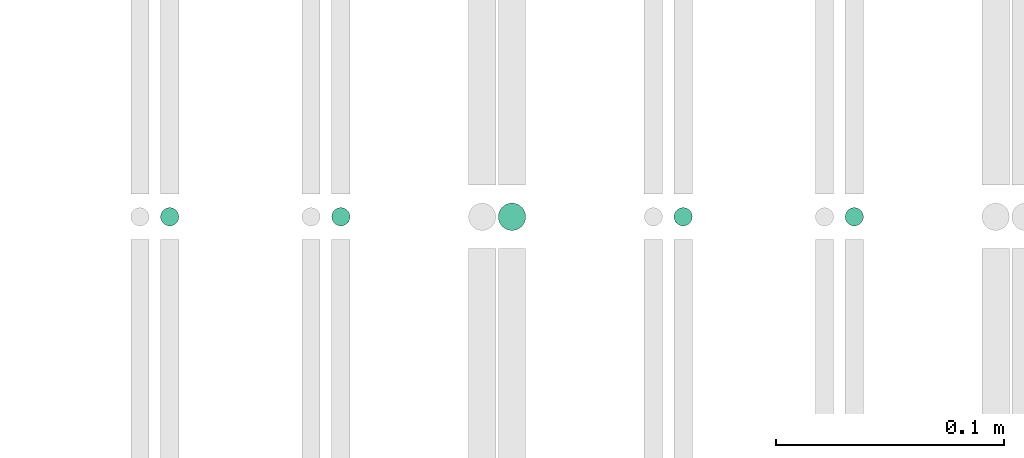
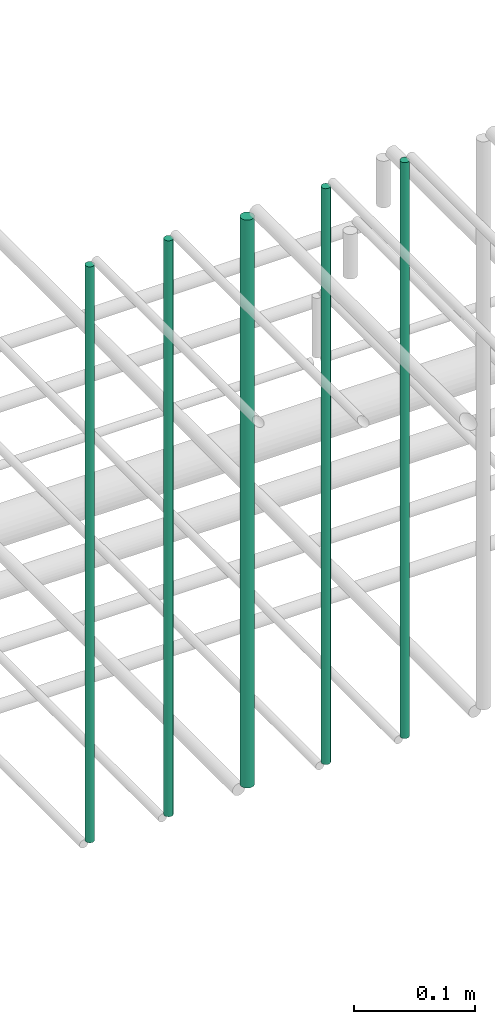
# One storey, part 144 of 331: 5 flow segments.
"""IFC2X3 building model written with IfcOpenShell, lengths in millimetres."""

import ifcopenshell
import ifcopenshell.guid

model = None  # the IFC model being written
_history = None  # IfcOwnerHistory: only IFC2X3 demands one
_inside = {}  # id of a spatial element -> (the spatial element, [elements in it])
_under = {}  # id of a project, library or spatial element -> (it, [spatial elements below it])
_declared = {}  # id of a project -> (the project, [libraries it declares])
_typed = {}  # id of a type object -> (the type object, [elements of that type])
_made_of = {}  # id of a material, layer set ... -> (it, [elements and type objects made of it])


def new_model(schema):
    """Start an empty IFC model of exactly this schema.

    Asked for "IFC4X3", IfcOpenShell would pick the latest addendum, in which some entities
    have other attributes; the version numbers below select the first issue.
    IFC2X3 requires an IfcOwnerHistory on every rooted entity: one is made here for all.
    """
    global model, _history
    if schema == "IFC4X3":
        model = ifcopenshell.file(schema_version=(4, 3, 0, 0))
    else:
        model = ifcopenshell.file(schema=schema)
    _inside.clear()
    _under.clear()
    _declared.clear()
    _typed.clear()
    _made_of.clear()
    _history = None
    if model.schema == "IFC2X3":
        org = make("IfcOrganization", Name="unknown")
        user = make(
            "IfcPersonAndOrganization",
            ThePerson=make("IfcPerson", FamilyName="unknown"),
            TheOrganization=org,
        )
        app = make(
            "IfcApplication",
            ApplicationDeveloper=org,
            Version="unknown",
            ApplicationFullName="unknown",
            ApplicationIdentifier="unknown",
        )
        _history = make(
            "IfcOwnerHistory",
            OwningUser=user,
            OwningApplication=app,
            ChangeAction="ADDED",
            CreationDate=0,
        )
    return model


def make(cls, **values):
    """One entity of the class cls with the attributes given. An attribute that is None is left unset."""
    return model.create_entity(
        cls, **{name: value for name, value in values.items() if value is not None}
    )


def entity(cls, *values):
    """Any entity or typed value of the class cls, its attributes in the order of the schema. None: left unset."""
    e = model.create_entity(cls)
    for i, value in enumerate(values):
        if value is not None:
            e[i] = value
    return e


def rooted(cls, **values):
    """An entity with a GlobalId (a new one), such as an element, a storey or a relation."""
    return make(cls, GlobalId=ifcopenshell.guid.new(), OwnerHistory=_history, **values)


def si_unit(unit_type, name, prefix=None):
    """IfcSIUnit, for example si_unit("LENGTHUNIT", "METRE", prefix="MILLI")."""
    return make("IfcSIUnit", UnitType=unit_type, Prefix=prefix, Name=name)


def converted_unit(unit_type, name, factor, base, dimensions=None, offset=None):
    """IfcConversionBasedUnit, such as the inch: factor (a typed value) times the base unit."""
    return make(
        "IfcConversionBasedUnit"
        if offset is None
        else "IfcConversionBasedUnitWithOffset",
        ConversionOffset=offset,
        Dimensions=None
        if dimensions is None
        else entity("IfcDimensionalExponents", *dimensions),
        UnitType=unit_type,
        Name=name,
        ConversionFactor=make(
            "IfcMeasureWithUnit", ValueComponent=factor, UnitComponent=base
        ),
    )


def derived_unit(unit_type, elements):
    """IfcDerivedUnit: a product of units, each with its exponent."""
    return make(
        "IfcDerivedUnit",
        Elements=[
            make("IfcDerivedUnitElement", Unit=unit, Exponent=power)
            for unit, power in elements
        ],
        UnitType=unit_type,
    )


def assignment(units):
    """IfcUnitAssignment: the units of a project."""
    return None if units is None else make("IfcUnitAssignment", Units=units)


def point(xyz):
    """IfcCartesianPoint."""
    return None if xyz is None else make("IfcCartesianPoint", Coordinates=xyz)


def direction(xyz):
    """IfcDirection."""
    return None if xyz is None else make("IfcDirection", DirectionRatios=xyz)


def frame(location, z_axis=None, x_axis=None):
    """IfcAxis2Placement3D, a coordinate frame: its origin and axes. An axis left out is left unset."""
    return make(
        "IfcAxis2Placement3D",
        Location=point(location),
        Axis=direction(z_axis),
        RefDirection=direction(x_axis),
    )


def frame_2d(location, x_axis=None):
    """IfcAxis2Placement2D, a coordinate frame in the plane: its origin and x axis."""
    return make(
        "IfcAxis2Placement2D", Location=point(location), RefDirection=direction(x_axis)
    )


def origin():
    """The frame at (0, 0, 0) with its axes left unset."""
    return frame((0.0, 0.0, 0.0))


def origin_2d_with_axis():
    """The frame at (0, 0) in the plane with the x axis (1, 0) written out."""
    return frame_2d((0.0, 0.0), x_axis=(1.0, 0.0))


def place(relative_to, where):
    """IfcLocalPlacement: puts the frame where relative to a parent placement (None: the world)."""
    return make(
        "IfcLocalPlacement", PlacementRelTo=relative_to, RelativePlacement=where
    )


def context(
    kind, dimensions, precision=None, world=None, true_north=None, identifier=None
):
    """IfcGeometricRepresentationContext, for example the 3D "Model" context."""
    return make(
        "IfcGeometricRepresentationContext",
        ContextIdentifier=identifier,
        ContextType=kind,
        CoordinateSpaceDimension=dimensions,
        Precision=precision,
        WorldCoordinateSystem=world,
        TrueNorth=true_north,
    )


def subcontext(parent, identifier, kind, view, scale=None):
    """IfcGeometricRepresentationSubContext, for example "Body" below "Model"."""
    return make(
        "IfcGeometricRepresentationSubContext",
        ContextIdentifier=identifier,
        ContextType=kind,
        ParentContext=parent,
        TargetScale=scale,
        TargetView=view,
    )


def project(units=None, contexts=None):
    """IfcProject with its units and contexts."""
    return rooted(
        "IfcProject",
        Name="project",
        RepresentationContexts=contexts,
        UnitsInContext=assignment(units),
    )


def spatial(cls, under=None, at=None, **own):
    """A site, building, storey or space (cls), placed at a placement, below another one or the project."""
    s = rooted(cls, ObjectPlacement=at, **own)
    if under is not None:
        _under.setdefault(under.id(), (under, []))[1].append(s)
    return s


def profile(cls, at=None, kind="AREA", **sizes):
    """A parametric profile (cls). Its sizes go by their IFC names, for example OverallWidth=200.0."""
    return make(cls, ProfileType=kind, Position=at, **sizes)


def circle(**sizes):
    """IfcCircleProfileDef."""
    return profile("IfcCircleProfileDef", **sizes)


def extrude(swept, where, along, depth):
    """IfcExtrudedAreaSolid: the profile swept, set in the frame where, extruded along a direction by depth."""
    return make(
        "IfcExtrudedAreaSolid",
        SweptArea=swept,
        Position=where,
        ExtrudedDirection=direction(along),
        Depth=depth,
    )


def shape(context_of_items, identifier, shape_type, items):
    """IfcShapeRepresentation: the items that make up one representation, for example the "Body"."""
    return make(
        "IfcShapeRepresentation",
        ContextOfItems=context_of_items,
        RepresentationIdentifier=identifier,
        RepresentationType=shape_type,
        Items=items,
    )


def made_of(thing, what):
    """Note that an element or type object is made of a material, layer set ...; save() writes the relation."""
    if what is not None:
        _made_of.setdefault(what.id(), (what, []))[1].append(thing)
    return thing


def type_object(cls, material=None, **own):
    """A type object (cls), such as IfcWallType, which elements share."""
    return made_of(rooted(cls, **own), material)


def element(
    cls,
    number,
    at=None,
    inside=None,
    cuts=None,
    type_object=None,
    material=None,
    context=None,
    identifier="Body",
    shape_type=None,
    held_by="IfcProductDefinitionShape",
    body=None,
    shapes=None,
    **own,
):
    """One element of the class cls, such as IfcWall. Its Tag is "e" and its number.

    at: its placement. inside: the storey or other place that contains it. cuts: it is an
    opening in that element (IfcRelVoidsElement). A single representation is given by context,
    identifier, shape_type and body (its items); several are given by shapes. held_by: the class
    of the entity that holds the representations. save() writes the other relations.
    """
    e = rooted(cls, Tag="e%d" % number, ObjectPlacement=at, **own)
    if body is not None:
        shapes = [shape(context, identifier, shape_type, body)]
    if shapes is not None:
        e.Representation = make(held_by, Representations=shapes)
    if inside is not None:
        _inside.setdefault(inside.id(), (inside, []))[1].append(e)
    if cuts is not None:
        rooted(
            "IfcRelVoidsElement", RelatingBuildingElement=cuts, RelatedOpeningElement=e
        )
    if type_object is not None:
        _typed.setdefault(type_object.id(), (type_object, []))[1].append(e)
    return made_of(e, material)


def aggregate(whole, parts):
    """IfcRelAggregates: a whole, such as a stair, and the parts it consists of."""
    return rooted("IfcRelAggregates", RelatingObject=whole, RelatedObjects=parts)


def save(model, path):
    """Write the relations noted so far, then the file.

    IfcRelAggregates (storeys below a building ...), IfcRelContainedInSpatialStructure (elements
    in a storey), IfcRelDefinesByType, IfcRelAssociatesMaterial and IfcRelDeclares: one each for
    every whole, place, type object, material and project.
    """
    for whole, parts in _under.values():
        aggregate(whole, parts)
    for where, things in _inside.values():
        rooted(
            "IfcRelContainedInSpatialStructure",
            RelatedElements=things,
            RelatingStructure=where,
        )
    for kind, things in _typed.values():
        rooted("IfcRelDefinesByType", RelatedObjects=things, RelatingType=kind)
    for what, things in _made_of.values():
        rooted("IfcRelAssociatesMaterial", RelatedObjects=things, RelatingMaterial=what)
    for by, libraries in _declared.values():
        rooted("IfcRelDeclares", RelatingContext=by, RelatedDefinitions=libraries)
    model.write(path)


model = new_model("IFC2X3")

# Units and contexts
model_context = context("Model", 3, precision=0.01, world=origin(), true_north=direction((6.12303176911189e-17, 1.0)))
body_context = subcontext(model_context, "Body", "Model", "MODEL_VIEW")
ifc_project = project(units=[si_unit("LENGTHUNIT", "METRE", prefix="MILLI"), si_unit("AREAUNIT", "SQUARE_METRE"), si_unit("VOLUMEUNIT", "CUBIC_METRE"), converted_unit("PLANEANGLEUNIT", "DEGREE", entity("IfcRatioMeasure", 0.0174532925199433), si_unit("PLANEANGLEUNIT", "RADIAN"), dimensions=[0, 0, 0, 0, 0, 0, 0]), si_unit("MASSUNIT", "GRAM", prefix="KILO"), derived_unit("MASSDENSITYUNIT", [(si_unit("MASSUNIT", "GRAM", prefix="KILO"), 1), (si_unit("LENGTHUNIT", "METRE"), -3)]), derived_unit("MOMENTOFINERTIAUNIT", [(si_unit("LENGTHUNIT", "METRE"), 4)]), si_unit("TIMEUNIT", "SECOND"), si_unit("FREQUENCYUNIT", "HERTZ"), si_unit("THERMODYNAMICTEMPERATUREUNIT", "DEGREE_CELSIUS"), derived_unit("THERMALTRANSMITTANCEUNIT", [(si_unit("MASSUNIT", "GRAM", prefix="KILO"), 1), (si_unit("THERMODYNAMICTEMPERATUREUNIT", "KELVIN"), -1), (si_unit("TIMEUNIT", "SECOND"), -3)]), derived_unit("VOLUMETRICFLOWRATEUNIT", [(si_unit("LENGTHUNIT", "METRE"), 3), (si_unit("TIMEUNIT", "SECOND"), -1)]), derived_unit("MASSFLOWRATEUNIT", [(si_unit("MASSUNIT", "GRAM", prefix="KILO"), 1), (si_unit("TIMEUNIT", "SECOND"), -1)]), derived_unit("ROTATIONALFREQUENCYUNIT", [(si_unit("TIMEUNIT", "SECOND"), -1)]), si_unit("ELECTRICCURRENTUNIT", "AMPERE"), si_unit("ELECTRICVOLTAGEUNIT", "VOLT"), si_unit("POWERUNIT", "WATT"), si_unit("FORCEUNIT", "NEWTON", prefix="KILO"), si_unit("ILLUMINANCEUNIT", "LUX"), si_unit("LUMINOUSFLUXUNIT", "LUMEN"), si_unit("LUMINOUSINTENSITYUNIT", "CANDELA"), derived_unit("USERDEFINED", [(si_unit("MASSUNIT", "GRAM", prefix="KILO"), -1), (si_unit("LENGTHUNIT", "METRE"), -2), (si_unit("TIMEUNIT", "SECOND"), 3), (si_unit("LUMINOUSFLUXUNIT", "LUMEN"), 1)]), derived_unit("LINEARVELOCITYUNIT", [(si_unit("LENGTHUNIT", "METRE"), 1), (si_unit("TIMEUNIT", "SECOND"), -1)]), si_unit("PRESSUREUNIT", "PASCAL"), derived_unit("USERDEFINED", [(si_unit("LENGTHUNIT", "METRE"), -2), (si_unit("MASSUNIT", "GRAM", prefix="KILO"), 1), (si_unit("TIMEUNIT", "SECOND"), -2)]), derived_unit("LINEARFORCEUNIT", [(si_unit("MASSUNIT", "GRAM", prefix="KILO"), 1), (si_unit("LENGTHUNIT", "METRE"), 1), (si_unit("TIMEUNIT", "SECOND"), -2), (si_unit("LENGTHUNIT", "METRE"), -1)]), derived_unit("PLANARFORCEUNIT", [(si_unit("MASSUNIT", "GRAM", prefix="KILO"), 1), (si_unit("LENGTHUNIT", "METRE"), 1), (si_unit("TIMEUNIT", "SECOND"), -2), (si_unit("LENGTHUNIT", "METRE"), -2)])], contexts=[model_context])

# Site, building, storey
site_placement = place(None, frame((0.0, -0.00077364408347762, 0.0)))
site = spatial("IfcSite", under=ifc_project, at=site_placement, CompositionType="ELEMENT")
building_placement = place(site_placement, origin())
building = spatial("IfcBuilding", under=site, at=building_placement, CompositionType="ELEMENT")
storey_placement = place(building_placement, origin())
storey = spatial("IfcBuildingStorey", under=building, at=storey_placement, CompositionType="ELEMENT", Elevation=0.0)

# Flow segments
pipe_segment_type = type_object("IfcPipeSegmentType", PredefinedType="NOTDEFINED")
flow_segment_1_placement = place(storey_placement, frame((34178.5132627125, 5638.02529159149, 14560.0)))
element("IfcFlowSegment", 1, at=flow_segment_1_placement, inside=storey, type_object=pipe_segment_type, context=body_context, shape_type="SweptSolid", body=[
    extrude(circle(Radius=4.0, at=frame_2d((0.0, -1.08286712929839e-12), x_axis=(1.0, 0.0))), frame((5.59527223591499, 5.59527223591499, 0.0), z_axis=(0.0, 0.0, 1.0), x_axis=(-1.0, 0.0, 0.0)), (0.0, 0.0, 1.0), 580.000000000018),
])
flow_segment_2_placement = place(storey_placement, frame((34253.5132627125, 5638.02529159149, 14560.0)))
element("IfcFlowSegment", 2, at=flow_segment_2_placement, inside=storey, type_object=pipe_segment_type, context=body_context, shape_type="SweptSolid", body=[
    extrude(circle(Radius=4.0, at=origin_2d_with_axis()), frame((5.59527223591499, 5.59527223591607, 0.0), z_axis=(0.0, 0.0, 1.0), x_axis=(-1.0, 0.0, 0.0)), (0.0, 0.0, 1.0), 580.000000000009),
])
flow_segment_3_placement = place(storey_placement, frame((34326.5132627125, 5636.02529159149, 14564.0)))
element("IfcFlowSegment", 3, at=flow_segment_3_placement, inside=storey, type_object=pipe_segment_type, context=body_context, shape_type="SweptSolid", body=[
    extrude(circle(Radius=6.0, at=frame_2d((0.0, -1.08286712929839e-12), x_axis=(1.0, 0.0))), frame((7.59527223591454, 7.59527223591454, 0.0), z_axis=(0.0, 0.0, 1.0), x_axis=(-1.0, 0.0, 0.0)), (0.0, 0.0, 1.0), 572.0),
])
flow_segment_4_placement = place(storey_placement, frame((34403.5132627125, 5638.02529159149, 14560.0)))
element("IfcFlowSegment", 4, at=flow_segment_4_placement, inside=storey, type_object=pipe_segment_type, context=body_context, shape_type="SweptSolid", body=[
    extrude(circle(Radius=4.0, at=origin_2d_with_axis()), frame((5.59527223591499, 5.59527223591607, 0.0), z_axis=(0.0, 0.0, 1.0), x_axis=(-1.0, 0.0, 0.0)), (0.0, 0.0, 1.0), 580.000000000018),
])
flow_segment_5_placement = place(storey_placement, frame((34478.5132627125, 5638.02529159149, 14560.0)))
element("IfcFlowSegment", 5, at=flow_segment_5_placement, inside=storey, type_object=pipe_segment_type, context=body_context, shape_type="SweptSolid", body=[
    extrude(circle(Radius=4.0, at=origin_2d_with_axis()), frame((5.59527223591499, 5.59527223591607, 0.0), z_axis=(0.0, 0.0, 1.0), x_axis=(-1.0, 0.0, 0.0)), (0.0, 0.0, 1.0), 580.0),
])

save(model, "model.ifc")
